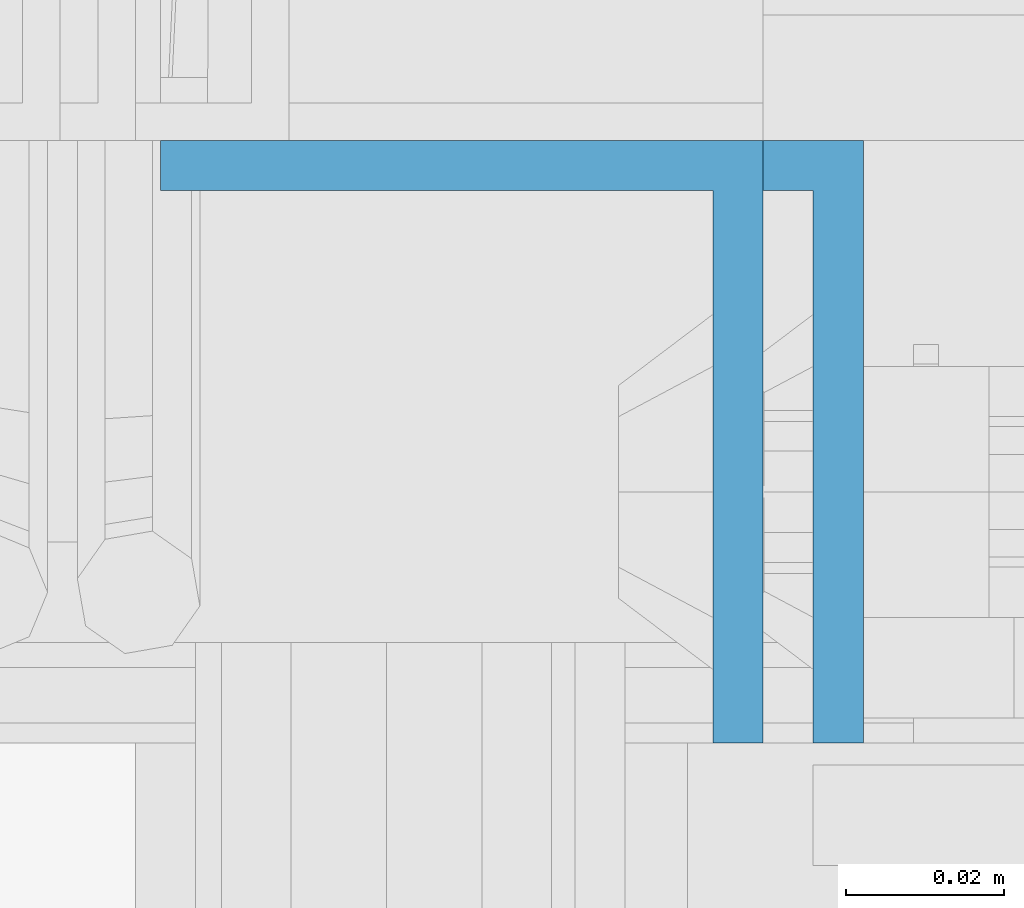
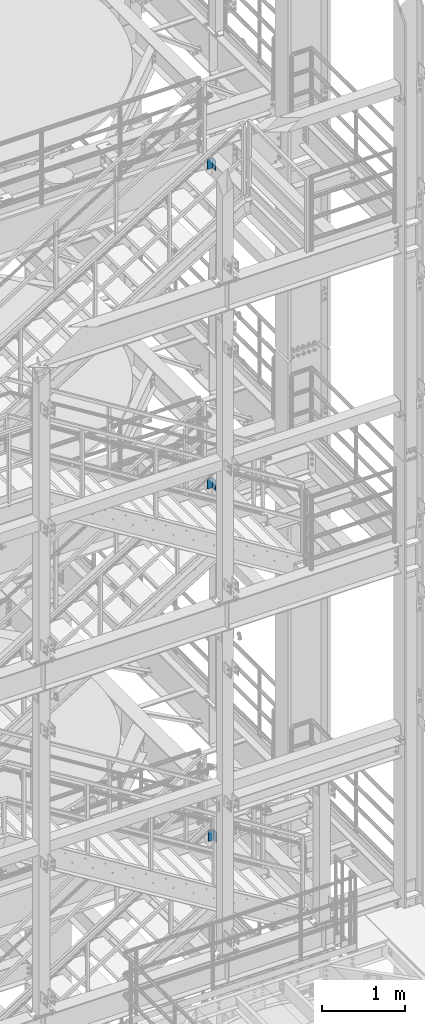
# One storey, part 828 of 1876: 3 columns, 3 elements without a shape of their own.
"""IFC2X3 building model written with IfcOpenShell, lengths in millimetres."""

from ifc_helpers import new_model, si_unit, frame, origin_with_axes, place, context, subcontext, project, spatial, faceted_brep, material, type_object, element, aggregate, save


model = new_model("IFC2X3")

# Units and contexts
model_context = context("Model", 3, precision=1e-05, world=origin_with_axes())
body_context = subcontext(model_context, "Body", "Model", "MODEL_VIEW")
ifc_project = project(units=[si_unit("LENGTHUNIT", "METRE", prefix="MILLI"), si_unit("AREAUNIT", "SQUARE_METRE"), si_unit("VOLUMEUNIT", "CUBIC_METRE"), si_unit("MASSUNIT", "GRAM", prefix="KILO"), si_unit("TIMEUNIT", "SECOND"), si_unit("PLANEANGLEUNIT", "RADIAN"), si_unit("SOLIDANGLEUNIT", "STERADIAN"), si_unit("THERMODYNAMICTEMPERATUREUNIT", "DEGREE_CELSIUS"), si_unit("LUMINOUSINTENSITYUNIT", "LUMEN")], contexts=[model_context])

# Site, building, storey
site_placement = place(None, origin_with_axes())
site = spatial("IfcSite", under=ifc_project, at=site_placement, CompositionType="ELEMENT")
building_placement = place(site_placement, origin_with_axes())
building = spatial("IfcBuilding", under=site, at=building_placement, Name="Undefined", CompositionType="ELEMENT")
storey_placement = place(building_placement, origin_with_axes())
storey = spatial("IfcBuildingStorey", under=building, at=storey_placement, Name="Undefined", CompositionType="ELEMENT", Elevation=0.0)

# Assembly, column
assembly_1_placement = place(storey_placement, origin_with_axes())
assembly_1 = element("IfcElementAssembly", 1, at=assembly_1_placement, inside=storey, Name="STRINGER", AssemblyPlace="NOTDEFINED", PredefinedType="RIGID_FRAME")
ifc_material = material(Name="STEEL/A36")
column_type = type_object("IfcColumnType", Name="L3X3X1/4", PredefinedType="NOTDEFINED")
column_1_placement = place(assembly_1_placement, frame((6207.12500000192, -4838.70000114118, 17802.2250011625), z_axis=(-1.0, 0.0, 0.0), x_axis=(0.0, 0.0, 1.0)))
column_1 = element("IfcColumn", 2, at=column_1_placement, type_object=column_type, material=ifc_material, Name="ANGLE", ObjectType="L3X3X1/4", context=body_context, shape_type="Brep", body=[
    faceted_brep([(0.0, 38.1000000000004, -38.1), (0.0, 38.1000000000004, 38.1), (152.4, 38.1000000000004, 38.1), (152.4, 38.1000000000004, -38.1), (0.0, 31.75, 38.1000000000004), (152.4, 31.75, 38.0999999999999), (0.0, 31.75, -31.75), (152.4, 31.75, -31.75), (0.0, -38.1000000000004, -31.75), (152.4, -38.1000000000004, -31.75), (0.0, -38.1000000000004, -38.1), (152.4, -38.1000000000004, -38.1)], [[[0, 1, 2, 3]], [[1, 4, 5, 2]], [[4, 6, 7, 5]], [[6, 8, 9, 7]], [[8, 10, 11, 9]], [[10, 0, 3, 11]], [[5, 7, 9, 11, 3, 2]], [[10, 8, 6, 4, 1, 0]]]),
])
aggregate(assembly_1, [column_1])

assembly_2_placement = place(storey_placement, origin_with_axes())
assembly_2 = element("IfcElementAssembly", 3, at=assembly_2_placement, inside=storey, Name="STRINGER", AssemblyPlace="NOTDEFINED", PredefinedType="RIGID_FRAME")
column_2_placement = place(assembly_2_placement, frame((6207.12500000103, -4838.70000114192, 13128.6250000172), z_axis=(-1.0, 0.0, 0.0), x_axis=(0.0, 0.0, 1.0)))
column_2 = element("IfcColumn", 4, at=column_2_placement, type_object=column_type, material=ifc_material, Name="ANGLE", ObjectType="L3X3X1/4", context=body_context, shape_type="Brep", body=[
    faceted_brep([(0.0, 38.1000000000004, -38.1), (0.0, 38.1000000000004, 38.1), (152.4, 38.1000000000004, 38.1), (152.4, 38.1000000000004, -38.1), (0.0, 31.75, 38.1000000000004), (152.4, 31.75, 38.0999999999999), (0.0, 31.75, -31.75), (152.4, 31.75, -31.75), (0.0, -38.1000000000004, -31.75), (152.4, -38.1000000000004, -31.75), (0.0, -38.1000000000004, -38.1), (152.4, -38.1000000000004, -38.1)], [[[0, 1, 2, 3]], [[1, 4, 5, 2]], [[4, 6, 7, 5]], [[6, 8, 9, 7]], [[8, 10, 11, 9]], [[10, 0, 3, 11]], [[5, 7, 9, 11, 3, 2]], [[10, 8, 6, 4, 1, 0]]]),
])
aggregate(assembly_2, [column_2])

assembly_3_placement = place(storey_placement, origin_with_axes())
assembly_3 = element("IfcElementAssembly", 5, at=assembly_3_placement, inside=storey, Name="STRINGER", AssemblyPlace="NOTDEFINED", PredefinedType="RIGID_FRAME")
column_3_placement = place(assembly_3_placement, frame((6219.82500000062, -4838.70000113598, 7972.42499863022), z_axis=(-1.0, 0.0, 0.0), x_axis=(0.0, 0.0, 1.0)))
column_3 = element("IfcColumn", 6, at=column_3_placement, type_object=column_type, material=ifc_material, Name="ANGLE", ObjectType="L3X3X1/4", context=body_context, shape_type="Brep", body=[
    faceted_brep([(0.0, 38.1000000000004, -38.1), (0.0, 38.1000000000004, 38.1), (152.4, 38.1000000000004, 38.1), (152.4, 38.1000000000004, -38.1), (0.0, 31.75, 38.1000000000004), (152.4, 31.75, 38.0999999999999), (0.0, 31.75, -31.75), (152.4, 31.75, -31.75), (0.0, -38.1000000000004, -31.75), (152.4, -38.1000000000004, -31.75), (0.0, -38.1000000000004, -38.1), (152.4, -38.1000000000004, -38.1)], [[[0, 1, 2, 3]], [[1, 4, 5, 2]], [[4, 6, 7, 5]], [[6, 8, 9, 7]], [[8, 10, 11, 9]], [[10, 0, 3, 11]], [[5, 7, 9, 11, 3, 2]], [[10, 8, 6, 4, 1, 0]]]),
])
aggregate(assembly_3, [column_3])

save(model, "model.ifc")
